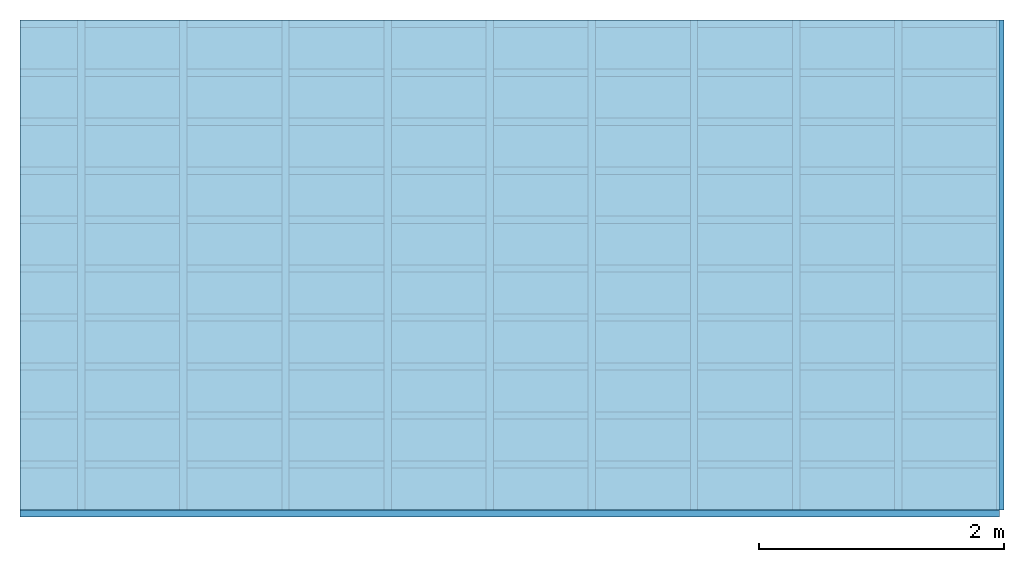
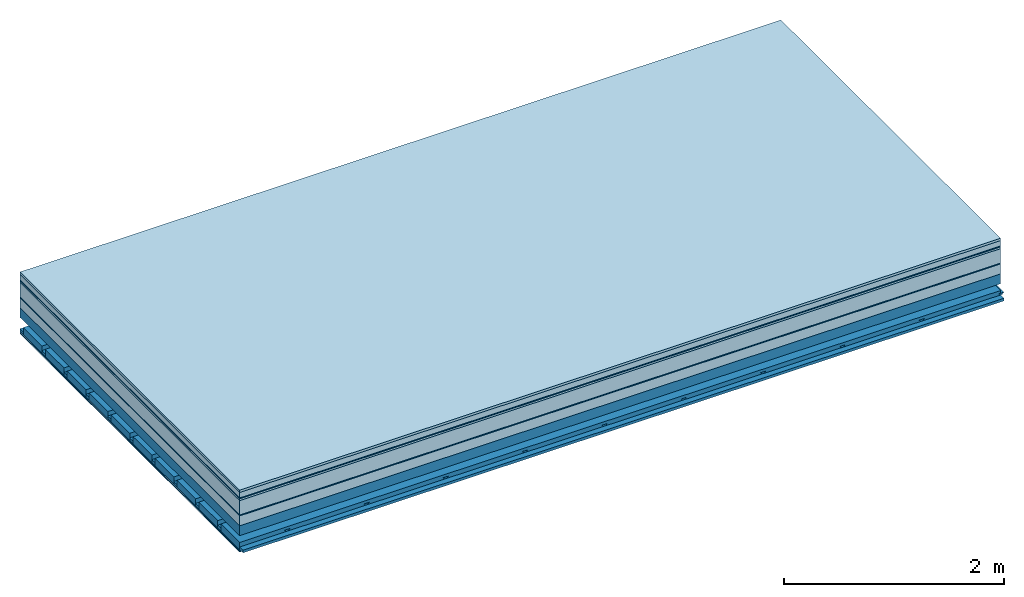
# One storey: 10 plates, 4 members, 1 element without a shape of its own.
"""IFC4 building model written with IfcOpenShell, lengths in metres."""

import ifcopenshell
import ifcopenshell.guid

model = None  # the IFC model being written
_history = None  # IfcOwnerHistory: only IFC2X3 demands one
_inside = {}  # id of a spatial element -> (the spatial element, [elements in it])
_under = {}  # id of a project, library or spatial element -> (it, [spatial elements below it])
_declared = {}  # id of a project -> (the project, [libraries it declares])
_typed = {}  # id of a type object -> (the type object, [elements of that type])
_made_of = {}  # id of a material, layer set ... -> (it, [elements and type objects made of it])


def new_model(schema):
    """Start an empty IFC model of exactly this schema.

    Asked for "IFC4X3", IfcOpenShell would pick the latest addendum, in which some entities
    have other attributes; the version numbers below select the first issue.
    IFC2X3 requires an IfcOwnerHistory on every rooted entity: one is made here for all.
    """
    global model, _history
    if schema == "IFC4X3":
        model = ifcopenshell.file(schema_version=(4, 3, 0, 0))
    else:
        model = ifcopenshell.file(schema=schema)
    _inside.clear()
    _under.clear()
    _declared.clear()
    _typed.clear()
    _made_of.clear()
    _history = None
    if model.schema == "IFC2X3":
        org = make("IfcOrganization", Name="unknown")
        user = make(
            "IfcPersonAndOrganization",
            ThePerson=make("IfcPerson", FamilyName="unknown"),
            TheOrganization=org,
        )
        app = make(
            "IfcApplication",
            ApplicationDeveloper=org,
            Version="unknown",
            ApplicationFullName="unknown",
            ApplicationIdentifier="unknown",
        )
        _history = make(
            "IfcOwnerHistory",
            OwningUser=user,
            OwningApplication=app,
            ChangeAction="ADDED",
            CreationDate=0,
        )
    return model


def make(cls, **values):
    """One entity of the class cls with the attributes given. An attribute that is None is left unset."""
    return model.create_entity(
        cls, **{name: value for name, value in values.items() if value is not None}
    )


def rooted(cls, **values):
    """An entity with a GlobalId (a new one), such as an element, a storey or a relation."""
    return make(cls, GlobalId=ifcopenshell.guid.new(), OwnerHistory=_history, **values)


def si_unit(unit_type, name, prefix=None):
    """IfcSIUnit, for example si_unit("LENGTHUNIT", "METRE", prefix="MILLI")."""
    return make("IfcSIUnit", UnitType=unit_type, Prefix=prefix, Name=name)


def derived_unit(unit_type, elements):
    """IfcDerivedUnit: a product of units, each with its exponent."""
    return make(
        "IfcDerivedUnit",
        Elements=[
            make("IfcDerivedUnitElement", Unit=unit, Exponent=power)
            for unit, power in elements
        ],
        UnitType=unit_type,
    )


def assignment(units):
    """IfcUnitAssignment: the units of a project."""
    return None if units is None else make("IfcUnitAssignment", Units=units)


def point(xyz):
    """IfcCartesianPoint."""
    return None if xyz is None else make("IfcCartesianPoint", Coordinates=xyz)


def direction(xyz):
    """IfcDirection."""
    return None if xyz is None else make("IfcDirection", DirectionRatios=xyz)


def frame(location, z_axis=None, x_axis=None):
    """IfcAxis2Placement3D, a coordinate frame: its origin and axes. An axis left out is left unset."""
    return make(
        "IfcAxis2Placement3D",
        Location=point(location),
        Axis=direction(z_axis),
        RefDirection=direction(x_axis),
    )


def frame_2d(location, x_axis=None):
    """IfcAxis2Placement2D, a coordinate frame in the plane: its origin and x axis."""
    return make(
        "IfcAxis2Placement2D", Location=point(location), RefDirection=direction(x_axis)
    )


def origin():
    """The frame at (0, 0, 0) with its axes left unset."""
    return frame((0.0, 0.0, 0.0))


def origin_with_axes():
    """The frame at (0, 0, 0) with the z axis (0, 0, 1) and the x axis (1, 0, 0) written out."""
    return frame((0.0, 0.0, 0.0), z_axis=(0.0, 0.0, 1.0), x_axis=(1.0, 0.0, 0.0))


def place(relative_to, where):
    """IfcLocalPlacement: puts the frame where relative to a parent placement (None: the world)."""
    return make(
        "IfcLocalPlacement", PlacementRelTo=relative_to, RelativePlacement=where
    )


def context(
    kind, dimensions, precision=None, world=None, true_north=None, identifier=None
):
    """IfcGeometricRepresentationContext, for example the 3D "Model" context."""
    return make(
        "IfcGeometricRepresentationContext",
        ContextIdentifier=identifier,
        ContextType=kind,
        CoordinateSpaceDimension=dimensions,
        Precision=precision,
        WorldCoordinateSystem=world,
        TrueNorth=true_north,
    )


def project(units=None, contexts=None):
    """IfcProject with its units and contexts."""
    return rooted(
        "IfcProject",
        Name="project",
        RepresentationContexts=contexts,
        UnitsInContext=assignment(units),
    )


def spatial(cls, under=None, at=None, **own):
    """A site, building, storey or space (cls), placed at a placement, below another one or the project."""
    s = rooted(cls, ObjectPlacement=at, **own)
    if under is not None:
        _under.setdefault(under.id(), (under, []))[1].append(s)
    return s


def polyline(points):
    """IfcPolyline through the points."""
    return make("IfcPolyline", Points=[point(p) for p in points])


def profile(cls, at=None, kind="AREA", **sizes):
    """A parametric profile (cls). Its sizes go by their IFC names, for example OverallWidth=200.0."""
    return make(cls, ProfileType=kind, Position=at, **sizes)


def rectangle(**sizes):
    """IfcRectangleProfileDef."""
    return profile("IfcRectangleProfileDef", **sizes)


def outline(outer, holes=None, kind="AREA"):
    """IfcArbitraryClosedProfileDef: a profile drawn as a closed curve; with holes, ...WithVoids."""
    if holes is None:
        return make("IfcArbitraryClosedProfileDef", ProfileType=kind, OuterCurve=outer)
    return make(
        "IfcArbitraryProfileDefWithVoids",
        ProfileType=kind,
        OuterCurve=outer,
        InnerCurves=holes,
    )


def extrude(swept, where, along, depth):
    """IfcExtrudedAreaSolid: the profile swept, set in the frame where, extruded along a direction by depth."""
    return make(
        "IfcExtrudedAreaSolid",
        SweptArea=swept,
        Position=where,
        ExtrudedDirection=direction(along),
        Depth=depth,
    )


def shape(context_of_items, identifier, shape_type, items):
    """IfcShapeRepresentation: the items that make up one representation, for example the "Body"."""
    return make(
        "IfcShapeRepresentation",
        ContextOfItems=context_of_items,
        RepresentationIdentifier=identifier,
        RepresentationType=shape_type,
        Items=items,
    )


def material(Name=None, Category=None):
    """IfcMaterial."""
    return make("IfcMaterial", Name=Name, Category=Category)


def layer(
    of_material, thickness, ventilated=None, Name=None, Category=None, Priority=None
):
    """IfcMaterialLayer: one layer of a wall or slab, of a material (None: an air gap)."""
    return make(
        "IfcMaterialLayer",
        Material=of_material,
        LayerThickness=thickness,
        IsVentilated=ventilated,
        Name=Name,
        Category=Category,
        Priority=Priority,
    )


def layer_set(layers, Name=None):
    """IfcMaterialLayerSet."""
    return make("IfcMaterialLayerSet", MaterialLayers=layers, LayerSetName=Name)


def made_of(thing, what):
    """Note that an element or type object is made of a material, layer set ...; save() writes the relation."""
    if what is not None:
        _made_of.setdefault(what.id(), (what, []))[1].append(thing)
    return thing


def type_object(cls, material=None, **own):
    """A type object (cls), such as IfcWallType, which elements share."""
    return made_of(rooted(cls, **own), material)


def element(
    cls,
    number,
    at=None,
    inside=None,
    cuts=None,
    type_object=None,
    material=None,
    context=None,
    identifier="Body",
    shape_type=None,
    held_by="IfcProductDefinitionShape",
    body=None,
    shapes=None,
    **own,
):
    """One element of the class cls, such as IfcWall. Its Tag is "e" and its number.

    at: its placement. inside: the storey or other place that contains it. cuts: it is an
    opening in that element (IfcRelVoidsElement). A single representation is given by context,
    identifier, shape_type and body (its items); several are given by shapes. held_by: the class
    of the entity that holds the representations. save() writes the other relations.
    """
    e = rooted(cls, Tag="e%d" % number, ObjectPlacement=at, **own)
    if body is not None:
        shapes = [shape(context, identifier, shape_type, body)]
    if shapes is not None:
        e.Representation = make(held_by, Representations=shapes)
    if inside is not None:
        _inside.setdefault(inside.id(), (inside, []))[1].append(e)
    if cuts is not None:
        rooted(
            "IfcRelVoidsElement", RelatingBuildingElement=cuts, RelatedOpeningElement=e
        )
    if type_object is not None:
        _typed.setdefault(type_object.id(), (type_object, []))[1].append(e)
    return made_of(e, material)


def aggregate(whole, parts):
    """IfcRelAggregates: a whole, such as a stair, and the parts it consists of."""
    return rooted("IfcRelAggregates", RelatingObject=whole, RelatedObjects=parts)


def save(model, path):
    """Write the relations noted so far, then the file.

    IfcRelAggregates (storeys below a building ...), IfcRelContainedInSpatialStructure (elements
    in a storey), IfcRelDefinesByType, IfcRelAssociatesMaterial and IfcRelDeclares: one each for
    every whole, place, type object, material and project.
    """
    for whole, parts in _under.values():
        aggregate(whole, parts)
    for where, things in _inside.values():
        rooted(
            "IfcRelContainedInSpatialStructure",
            RelatedElements=things,
            RelatingStructure=where,
        )
    for kind, things in _typed.values():
        rooted("IfcRelDefinesByType", RelatedObjects=things, RelatingType=kind)
    for what, things in _made_of.values():
        rooted("IfcRelAssociatesMaterial", RelatedObjects=things, RelatingMaterial=what)
    for by, libraries in _declared.values():
        rooted("IfcRelDeclares", RelatingContext=by, RelatedDefinitions=libraries)
    model.write(path)


model = new_model("IFC4")

# Units and contexts
plan_context = context("Plan", 3, precision=1e-05, world=origin(), true_north=direction((0.0, 1.0)))
model_context = context("Model", 3, precision=1e-05, world=origin(), true_north=direction((0.0, 1.0)))
ifc_project = project(units=[si_unit("LENGTHUNIT", "METRE"), derived_unit("SOUNDPRESSUREUNIT", [(si_unit("PRESSUREUNIT", "PASCAL", prefix="MICRO"), 0)]), si_unit("ENERGYUNIT", "JOULE", prefix="MEGA"), si_unit("MASSUNIT", "GRAM", prefix="KILO"), derived_unit("THERMALTRANSMITTANCEUNIT", [(si_unit("POWERUNIT", "WATT"), 1), (si_unit("AREAUNIT", "SQUARE_METRE"), -1), (si_unit("THERMODYNAMICTEMPERATUREUNIT", "KELVIN"), -1)]), derived_unit("AREADENSITYUNIT", [(si_unit("MASSUNIT", "GRAM", prefix="KILO"), 1), (si_unit("AREAUNIT", "SQUARE_METRE"), -1)]), derived_unit("USERDEFINED", [(si_unit("ENERGYUNIT", "JOULE", prefix="MEGA"), 1), (si_unit("AREAUNIT", "SQUARE_METRE"), -1)])], contexts=[plan_context, model_context])

# Site, building, storey
site = spatial("IfcSite", under=ifc_project)
building_placement = place(None, origin())
building = spatial("IfcBuilding", under=site, at=building_placement)
storey_placement = place(building_placement, origin())
storey = spatial("IfcBuildingStorey", under=building, at=storey_placement)

# Slab, members, plates
ifc_material_1 = material(Category="07.009")
ifc_layer_1 = layer(ifc_material_1, 0.026, Name="Use and protection layer 3")
ifc_material_2 = material(Category="07.011")
ifc_layer_2 = layer(ifc_material_2, 0.06, Name="Use and protection layer 2")
ifc_material_3 = material(Name="Protective layer + Fire protection cover RF1", Category="09.007")
ifc_layer_3 = layer(ifc_material_3, 0.01, Name="Use and protection layer 1")
ifc_material_4 = material(Name="Bituminous", Category="09.003")
ifc_layer_4 = layer(ifc_material_4, 0.02, Name="Seal")
ifc_material_5 = material(Name="Mineral wool", Category="10.008")
ifc_layer_5 = layer(ifc_material_5, 0.16, Name="Exterior insulation layer 1")
ifc_material_6 = material(Name="Vapor-permeable barrier", Category="09.006")
ifc_layer_6 = layer(ifc_material_6, 0.01, Name="layer / temporary roof")
ifc_material_7 = material(Category="01.002")
ifc_layer_7 = layer(ifc_material_7, 0.11, Name="above 1st layer")
ifc_material_8 = material(Name="Rigid, of the art")
ifc_layer_8 = layer(ifc_material_8, 0.0, Name="Bond")
ifc_layer_9 = layer(None, 0.11, Name="Support")
ifc_material_9 = material(Name="no composite action")
ifc_layer_10 = layer(ifc_material_9, 0.0, Name="Bond")
ifc_layer_11 = layer(None, 0.125, Name="Coupling")
ifc_layer_12 = layer(None, 0.03, Name="Battens / profiles")
ifc_material_10 = material(Name="Plasterboard type A", Category="03.008")
ifc_layer_13 = layer(ifc_material_10, 0.0125, Name="Covering below 1st layer")
ifc_layer_14 = layer(ifc_material_10, 0.0125, Name="Covering below 2nd layer")
ifc_material_11 = material(Category="04.001")
ifc_layer_15 = layer(ifc_material_11, 0.003, Name="Surface below")
ifc_layer_set = layer_set([ifc_layer_1, ifc_layer_2, ifc_layer_3, ifc_layer_4, ifc_layer_5, ifc_layer_6, ifc_layer_7, ifc_layer_8, ifc_layer_9, ifc_layer_10, ifc_layer_11, ifc_layer_12, ifc_layer_13, ifc_layer_14, ifc_layer_15])
slab_type = type_object("IfcSlabType", Name="F0088", PredefinedType="NOTDEFINED", material=ifc_layer_set)
slab_placement = place(None, frame((0.0, 0.0, 0.0), z_axis=(0.0, 0.0, -1.0), x_axis=(1.0, 0.0, 0.0)))
slab = element("IfcSlab", 1, at=slab_placement, inside=storey, type_object=slab_type, material=ifc_layer_set, Name="Slab #1")
ifc_material_12 = material(Name="Solid timber panel")
member_1_placement = place(slab_placement, origin())
member_1 = element("IfcMember", 2, at=member_1_placement, material=ifc_material_12, Name="Support", context=plan_context, shape_type="SweptSolid", body=[
    extrude(rectangle(XDim=1.0, YDim=0.11, at=frame_2d((0.5, 0.055), x_axis=(1.0, 0.0))), frame((0.0, 4.0, 0.396), z_axis=(0.0, -1.0, 0.0), x_axis=(1.0, 0.0, 0.0)), (0.0, 0.0, 1.0), 4.0),
    extrude(rectangle(XDim=1.0, YDim=0.11, at=frame_2d((0.5, 0.055), x_axis=(1.0, 0.0))), frame((1.0, 4.0, 0.396), z_axis=(0.0, -1.0, 0.0), x_axis=(1.0, 0.0, 0.0)), (0.0, 0.0, 1.0), 4.0),
    extrude(rectangle(XDim=1.0, YDim=0.11, at=frame_2d((0.5, 0.055), x_axis=(1.0, 0.0))), frame((2.0, 4.0, 0.396), z_axis=(0.0, -1.0, 0.0), x_axis=(1.0, 0.0, 0.0)), (0.0, 0.0, 1.0), 4.0),
    extrude(rectangle(XDim=1.0, YDim=0.11, at=frame_2d((0.5, 0.055), x_axis=(1.0, 0.0))), frame((3.0, 4.0, 0.396), z_axis=(0.0, -1.0, 0.0), x_axis=(1.0, 0.0, 0.0)), (0.0, 0.0, 1.0), 4.0),
    extrude(rectangle(XDim=1.0, YDim=0.11, at=frame_2d((0.5, 0.055), x_axis=(1.0, 0.0))), frame((4.0, 4.0, 0.396), z_axis=(0.0, -1.0, 0.0), x_axis=(1.0, 0.0, 0.0)), (0.0, 0.0, 1.0), 4.0),
    extrude(rectangle(XDim=1.0, YDim=0.11, at=frame_2d((0.5, 0.055), x_axis=(1.0, 0.0))), frame((5.0, 4.0, 0.396), z_axis=(0.0, -1.0, 0.0), x_axis=(1.0, 0.0, 0.0)), (0.0, 0.0, 1.0), 4.0),
    extrude(rectangle(XDim=1.0, YDim=0.11, at=frame_2d((0.5, 0.055), x_axis=(1.0, 0.0))), frame((6.0, 4.0, 0.396), z_axis=(0.0, -1.0, 0.0), x_axis=(1.0, 0.0, 0.0)), (0.0, 0.0, 1.0), 4.0),
    extrude(rectangle(XDim=1.0, YDim=0.11, at=frame_2d((0.5, 0.055), x_axis=(1.0, 0.0))), frame((7.0, 4.0, 0.396), z_axis=(0.0, -1.0, 0.0), x_axis=(1.0, 0.0, 0.0)), (0.0, 0.0, 1.0), 4.0),
])
ifc_material_13 = material()
member_2_placement = place(slab_placement, origin())
member_2 = element("IfcMember", 3, at=member_2_placement, material=ifc_material_13, Name="Coupling", context=plan_context, shape_type="SweptSolid", body=[
    extrude(outline(polyline([(0.0, 0.0), (0.06, 0.0), (0.04, 0.02), (0.02, 0.02), (0.0, 0.0)])), frame((0.47, 4.0, 0.611), z_axis=(0.0, -1.0, 0.0), x_axis=(1.0, 0.0, 0.0)), (0.0, 0.0, 1.0), 4.0),
    extrude(outline(polyline([(0.0, 0.0), (0.06, 0.0), (0.04, 0.02), (0.02, 0.02), (0.0, 0.0)])), frame((1.304, 4.0, 0.611), z_axis=(0.0, -1.0, 0.0), x_axis=(1.0, 0.0, 0.0)), (0.0, 0.0, 1.0), 4.0),
    extrude(outline(polyline([(0.0, 0.0), (0.06, 0.0), (0.04, 0.02), (0.02, 0.02), (0.0, 0.0)])), frame((2.138, 4.0, 0.611), z_axis=(0.0, -1.0, 0.0), x_axis=(1.0, 0.0, 0.0)), (0.0, 0.0, 1.0), 4.0),
    extrude(outline(polyline([(0.0, 0.0), (0.06, 0.0), (0.04, 0.02), (0.02, 0.02), (0.0, 0.0)])), frame((2.972, 4.0, 0.611), z_axis=(0.0, -1.0, 0.0), x_axis=(1.0, 0.0, 0.0)), (0.0, 0.0, 1.0), 4.0),
    extrude(outline(polyline([(0.0, 0.0), (0.06, 0.0), (0.04, 0.02), (0.02, 0.02), (0.0, 0.0)])), frame((3.806, 4.0, 0.611), z_axis=(0.0, -1.0, 0.0), x_axis=(1.0, 0.0, 0.0)), (0.0, 0.0, 1.0), 4.0),
    extrude(outline(polyline([(0.0, 0.0), (0.06, 0.0), (0.04, 0.02), (0.02, 0.02), (0.0, 0.0)])), frame((4.64, 4.0, 0.611), z_axis=(0.0, -1.0, 0.0), x_axis=(1.0, 0.0, 0.0)), (0.0, 0.0, 1.0), 4.0),
    extrude(outline(polyline([(0.0, 0.0), (0.06, 0.0), (0.04, 0.02), (0.02, 0.02), (0.0, 0.0)])), frame((5.474, 4.0, 0.611), z_axis=(0.0, -1.0, 0.0), x_axis=(1.0, 0.0, 0.0)), (0.0, 0.0, 1.0), 4.0),
    extrude(outline(polyline([(0.0, 0.0), (0.06, 0.0), (0.04, 0.02), (0.02, 0.02), (0.0, 0.0)])), frame((6.308, 4.0, 0.611), z_axis=(0.0, -1.0, 0.0), x_axis=(1.0, 0.0, 0.0)), (0.0, 0.0, 1.0), 4.0),
    extrude(outline(polyline([(0.0, 0.0), (0.06, 0.0), (0.04, 0.02), (0.02, 0.02), (0.0, 0.0)])), frame((7.142, 4.0, 0.611), z_axis=(0.0, -1.0, 0.0), x_axis=(1.0, 0.0, 0.0)), (0.0, 0.0, 1.0), 4.0),
    extrude(outline(polyline([(0.0, 0.0), (0.06, 0.0), (0.04, 0.02), (0.02, 0.02), (0.0, 0.0)])), frame((7.976, 4.0, 0.611), z_axis=(0.0, -1.0, 0.0), x_axis=(1.0, 0.0, 0.0)), (0.0, 0.0, 1.0), 4.0),
])
member_3_placement = place(slab_placement, origin())
member_3 = element("IfcMember", 4, at=member_3_placement, material=ifc_material_13, Name="Battens / profiles", context=plan_context, shape_type="SweptSolid", body=[
    extrude(rectangle(XDim=0.06, YDim=0.03, at=frame_2d((0.03, 0.015), x_axis=(1.0, 0.0))), frame((0.0, 0.0, 0.631), z_axis=(1.0, 0.0, 0.0), x_axis=(0.0, 1.0, 0.0)), (0.0, 0.0, 1.0), 8.0),
    extrude(rectangle(XDim=0.06, YDim=0.03, at=frame_2d((0.03, 0.015), x_axis=(1.0, 0.0))), frame((0.0, 0.4, 0.631), z_axis=(1.0, 0.0, 0.0), x_axis=(0.0, 1.0, 0.0)), (0.0, 0.0, 1.0), 8.0),
    extrude(rectangle(XDim=0.06, YDim=0.03, at=frame_2d((0.03, 0.015), x_axis=(1.0, 0.0))), frame((0.0, 0.8, 0.631), z_axis=(1.0, 0.0, 0.0), x_axis=(0.0, 1.0, 0.0)), (0.0, 0.0, 1.0), 8.0),
    extrude(rectangle(XDim=0.06, YDim=0.03, at=frame_2d((0.03, 0.015), x_axis=(1.0, 0.0))), frame((0.0, 1.2, 0.631), z_axis=(1.0, 0.0, 0.0), x_axis=(0.0, 1.0, 0.0)), (0.0, 0.0, 1.0), 8.0),
    extrude(rectangle(XDim=0.06, YDim=0.03, at=frame_2d((0.03, 0.015), x_axis=(1.0, 0.0))), frame((0.0, 1.6, 0.631), z_axis=(1.0, 0.0, 0.0), x_axis=(0.0, 1.0, 0.0)), (0.0, 0.0, 1.0), 8.0),
    extrude(rectangle(XDim=0.06, YDim=0.03, at=frame_2d((0.03, 0.015), x_axis=(1.0, 0.0))), frame((0.0, 2.0, 0.631), z_axis=(1.0, 0.0, 0.0), x_axis=(0.0, 1.0, 0.0)), (0.0, 0.0, 1.0), 8.0),
    extrude(rectangle(XDim=0.06, YDim=0.03, at=frame_2d((0.03, 0.015), x_axis=(1.0, 0.0))), frame((0.0, 2.4, 0.631), z_axis=(1.0, 0.0, 0.0), x_axis=(0.0, 1.0, 0.0)), (0.0, 0.0, 1.0), 8.0),
    extrude(rectangle(XDim=0.06, YDim=0.03, at=frame_2d((0.03, 0.015), x_axis=(1.0, 0.0))), frame((0.0, 2.8, 0.631), z_axis=(1.0, 0.0, 0.0), x_axis=(0.0, 1.0, 0.0)), (0.0, 0.0, 1.0), 8.0),
    extrude(rectangle(XDim=0.06, YDim=0.03, at=frame_2d((0.03, 0.015), x_axis=(1.0, 0.0))), frame((0.0, 3.2, 0.631), z_axis=(1.0, 0.0, 0.0), x_axis=(0.0, 1.0, 0.0)), (0.0, 0.0, 1.0), 8.0),
    extrude(rectangle(XDim=0.06, YDim=0.03, at=frame_2d((0.03, 0.015), x_axis=(1.0, 0.0))), frame((0.0, 3.6, 0.631), z_axis=(1.0, 0.0, 0.0), x_axis=(0.0, 1.0, 0.0)), (0.0, 0.0, 1.0), 8.0),
    extrude(rectangle(XDim=0.06, YDim=0.03, at=frame_2d((0.03, 0.015), x_axis=(1.0, 0.0))), frame((0.0, 4.0, 0.631), z_axis=(1.0, 0.0, 0.0), x_axis=(0.0, 1.0, 0.0)), (0.0, 0.0, 1.0), 8.0),
])
ifc_material_14 = material()
member_4_placement = place(slab_placement, origin())
member_4 = element("IfcMember", 5, at=member_4_placement, material=ifc_material_14, Name="Cavity", context=plan_context, shape_type="SweptSolid", body=[
    extrude(rectangle(XDim=0.34, YDim=0.08, at=frame_2d((0.17, 0.04), x_axis=(1.0, 0.0))), frame((0.0, 0.06, 0.581), z_axis=(1.0, 0.0, 0.0), x_axis=(0.0, 1.0, 0.0)), (0.0, 0.0, 1.0), 8.0),
    extrude(rectangle(XDim=0.34, YDim=0.08, at=frame_2d((0.17, 0.04), x_axis=(1.0, 0.0))), frame((0.0, 0.46, 0.581), z_axis=(1.0, 0.0, 0.0), x_axis=(0.0, 1.0, 0.0)), (0.0, 0.0, 1.0), 8.0),
    extrude(rectangle(XDim=0.34, YDim=0.08, at=frame_2d((0.17, 0.04), x_axis=(1.0, 0.0))), frame((0.0, 0.86, 0.581), z_axis=(1.0, 0.0, 0.0), x_axis=(0.0, 1.0, 0.0)), (0.0, 0.0, 1.0), 8.0),
    extrude(rectangle(XDim=0.34, YDim=0.08, at=frame_2d((0.17, 0.04), x_axis=(1.0, 0.0))), frame((0.0, 1.26, 0.581), z_axis=(1.0, 0.0, 0.0), x_axis=(0.0, 1.0, 0.0)), (0.0, 0.0, 1.0), 8.0),
    extrude(rectangle(XDim=0.34, YDim=0.08, at=frame_2d((0.17, 0.04), x_axis=(1.0, 0.0))), frame((0.0, 1.66, 0.581), z_axis=(1.0, 0.0, 0.0), x_axis=(0.0, 1.0, 0.0)), (0.0, 0.0, 1.0), 8.0),
    extrude(rectangle(XDim=0.34, YDim=0.08, at=frame_2d((0.17, 0.04), x_axis=(1.0, 0.0))), frame((0.0, 2.06, 0.581), z_axis=(1.0, 0.0, 0.0), x_axis=(0.0, 1.0, 0.0)), (0.0, 0.0, 1.0), 8.0),
    extrude(rectangle(XDim=0.34, YDim=0.08, at=frame_2d((0.17, 0.04), x_axis=(1.0, 0.0))), frame((0.0, 2.46, 0.581), z_axis=(1.0, 0.0, 0.0), x_axis=(0.0, 1.0, 0.0)), (0.0, 0.0, 1.0), 8.0),
    extrude(rectangle(XDim=0.34, YDim=0.08, at=frame_2d((0.17, 0.04), x_axis=(1.0, 0.0))), frame((0.0, 2.86, 0.581), z_axis=(1.0, 0.0, 0.0), x_axis=(0.0, 1.0, 0.0)), (0.0, 0.0, 1.0), 8.0),
    extrude(rectangle(XDim=0.34, YDim=0.08, at=frame_2d((0.17, 0.04), x_axis=(1.0, 0.0))), frame((0.0, 3.26, 0.581), z_axis=(1.0, 0.0, 0.0), x_axis=(0.0, 1.0, 0.0)), (0.0, 0.0, 1.0), 8.0),
    extrude(rectangle(XDim=0.34, YDim=0.08, at=frame_2d((0.17, 0.04), x_axis=(1.0, 0.0))), frame((0.0, 3.66, 0.581), z_axis=(1.0, 0.0, 0.0), x_axis=(0.0, 1.0, 0.0)), (0.0, 0.0, 1.0), 8.0),
])
plate_1_placement = place(slab_placement, origin())
plate_1 = element("IfcPlate", 6, at=plate_1_placement, material=ifc_material_1, Name="Use and protection layer 3", context=plan_context, shape_type="SweptSolid", body=[
    extrude(rectangle(XDim=8.0, YDim=4.0, at=frame_2d((4.0, 2.0), x_axis=(1.0, 0.0))), origin_with_axes(), (0.0, 0.0, 1.0), 0.026),
])
plate_2_placement = place(slab_placement, origin())
plate_2 = element("IfcPlate", 7, at=plate_2_placement, material=ifc_material_2, Name="Use and protection layer 2", context=plan_context, shape_type="SweptSolid", body=[
    extrude(rectangle(XDim=8.0, YDim=4.0, at=frame_2d((4.0, 2.0), x_axis=(1.0, 0.0))), frame((0.0, 0.0, 0.026), z_axis=(0.0, 0.0, 1.0), x_axis=(1.0, 0.0, 0.0)), (0.0, 0.0, 1.0), 0.06),
])
plate_3_placement = place(slab_placement, origin())
plate_3 = element("IfcPlate", 8, at=plate_3_placement, material=ifc_material_3, Name="Use and protection layer 1", context=plan_context, shape_type="SweptSolid", body=[
    extrude(rectangle(XDim=8.0, YDim=4.0, at=frame_2d((4.0, 2.0), x_axis=(1.0, 0.0))), frame((0.0, 0.0, 0.086), z_axis=(0.0, 0.0, 1.0), x_axis=(1.0, 0.0, 0.0)), (0.0, 0.0, 1.0), 0.01),
])
plate_4_placement = place(slab_placement, origin())
plate_4 = element("IfcPlate", 9, at=plate_4_placement, material=ifc_material_4, Name="Seal", context=plan_context, shape_type="SweptSolid", body=[
    extrude(rectangle(XDim=8.0, YDim=4.0, at=frame_2d((4.0, 2.0), x_axis=(1.0, 0.0))), frame((0.0, 0.0, 0.096), z_axis=(0.0, 0.0, 1.0), x_axis=(1.0, 0.0, 0.0)), (0.0, 0.0, 1.0), 0.02),
])
plate_5_placement = place(slab_placement, origin())
plate_5 = element("IfcPlate", 10, at=plate_5_placement, material=ifc_material_5, Name="Exterior insulation layer 1", context=plan_context, shape_type="SweptSolid", body=[
    extrude(rectangle(XDim=8.0, YDim=4.0, at=frame_2d((4.0, 2.0), x_axis=(1.0, 0.0))), frame((0.0, 0.0, 0.116), z_axis=(0.0, 0.0, 1.0), x_axis=(1.0, 0.0, 0.0)), (0.0, 0.0, 1.0), 0.16),
])
plate_6_placement = place(slab_placement, origin())
plate_6 = element("IfcPlate", 11, at=plate_6_placement, material=ifc_material_6, Name="layer / temporary roof", context=plan_context, shape_type="SweptSolid", body=[
    extrude(rectangle(XDim=8.0, YDim=4.0, at=frame_2d((4.0, 2.0), x_axis=(1.0, 0.0))), frame((0.0, 0.0, 0.276), z_axis=(0.0, 0.0, 1.0), x_axis=(1.0, 0.0, 0.0)), (0.0, 0.0, 1.0), 0.01),
])
plate_7_placement = place(slab_placement, origin())
plate_7 = element("IfcPlate", 12, at=plate_7_placement, material=ifc_material_7, Name="above 1st layer", context=plan_context, shape_type="SweptSolid", body=[
    extrude(rectangle(XDim=8.0, YDim=4.0, at=frame_2d((4.0, 2.0), x_axis=(1.0, 0.0))), frame((0.0, 0.0, 0.286), z_axis=(0.0, 0.0, 1.0), x_axis=(1.0, 0.0, 0.0)), (0.0, 0.0, 1.0), 0.11),
])
plate_8_placement = place(slab_placement, origin())
plate_8 = element("IfcPlate", 13, at=plate_8_placement, material=ifc_material_10, Name="Covering below 1st layer", context=plan_context, shape_type="SweptSolid", body=[
    extrude(rectangle(XDim=8.0, YDim=4.0, at=frame_2d((4.0, 2.0), x_axis=(1.0, 0.0))), frame((0.0, 0.0, 0.661), z_axis=(0.0, 0.0, 1.0), x_axis=(1.0, 0.0, 0.0)), (0.0, 0.0, 1.0), 0.0125),
])
plate_9_placement = place(slab_placement, origin())
plate_9 = element("IfcPlate", 14, at=plate_9_placement, material=ifc_material_10, Name="Covering below 2nd layer", context=plan_context, shape_type="SweptSolid", body=[
    extrude(rectangle(XDim=8.0, YDim=4.0, at=frame_2d((4.0, 2.0), x_axis=(1.0, 0.0))), frame((0.0, 0.0, 0.6735), z_axis=(0.0, 0.0, 1.0), x_axis=(1.0, 0.0, 0.0)), (0.0, 0.0, 1.0), 0.0125),
])
plate_10_placement = place(slab_placement, origin())
plate_10 = element("IfcPlate", 15, at=plate_10_placement, material=ifc_material_11, Name="Surface below", context=plan_context, shape_type="SweptSolid", body=[
    extrude(rectangle(XDim=8.0, YDim=4.0, at=frame_2d((4.0, 2.0), x_axis=(1.0, 0.0))), frame((0.0, 0.0, 0.686), z_axis=(0.0, 0.0, 1.0), x_axis=(1.0, 0.0, 0.0)), (0.0, 0.0, 1.0), 0.003),
])
aggregate(slab, [plate_1, plate_2, plate_3, plate_4, plate_5, plate_6, plate_7, member_1, member_2, member_3, member_4, plate_8, plate_9, plate_10])

save(model, "model.ifc")
